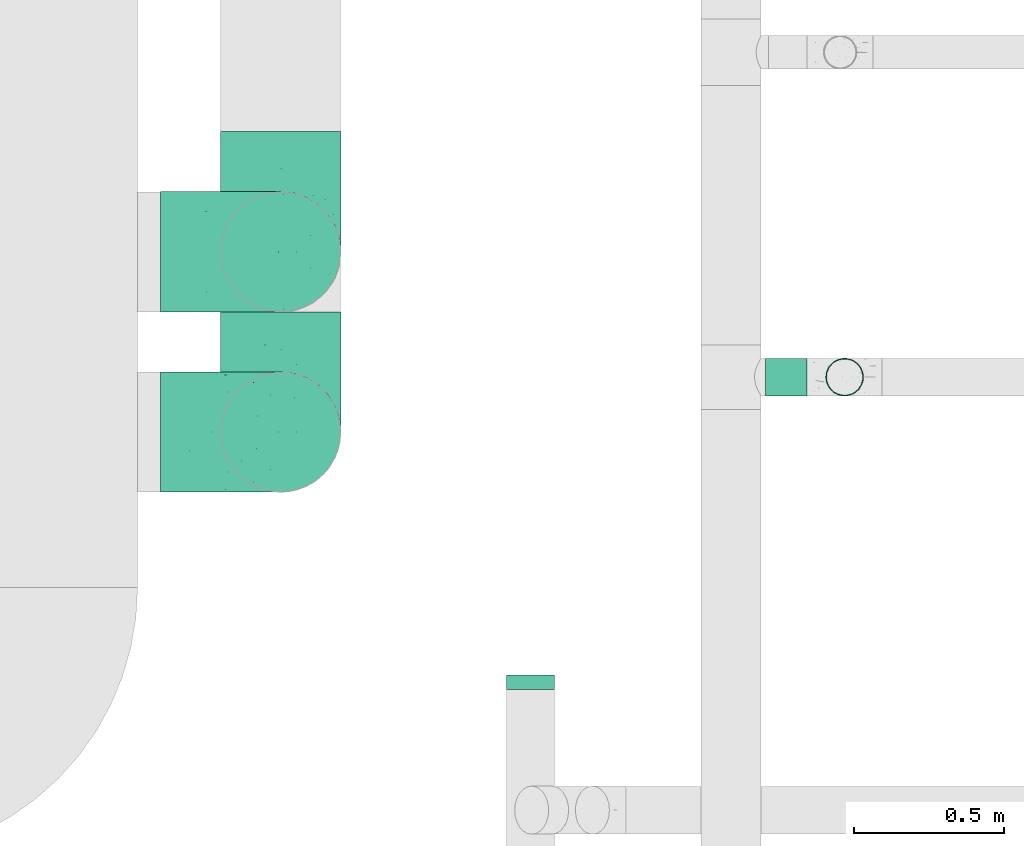
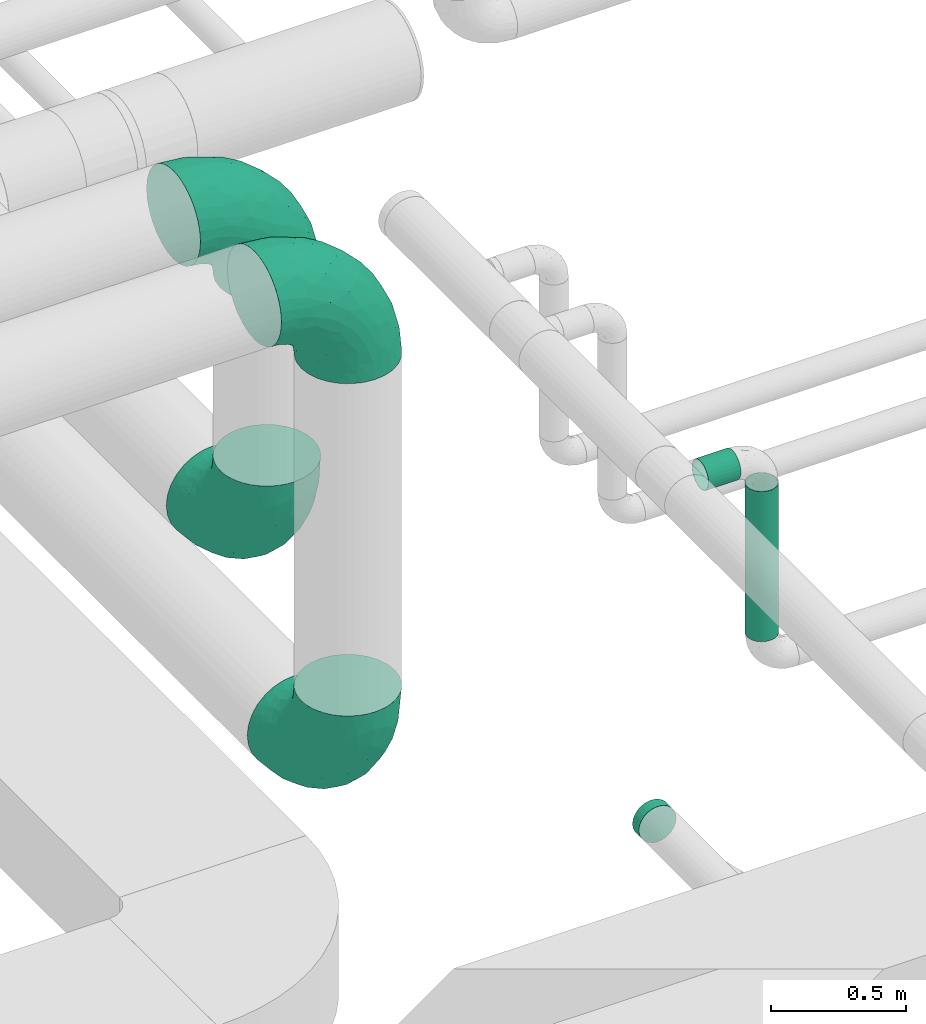
# One storey, part 64 of 91: 5 flow fittings, 2 flow segments.
"""IFC2X3 building model written with IfcOpenShell, lengths in millimetres."""

from ifc_helpers import new_model, entity, si_unit, converted_unit, derived_unit, direction, frame, origin_with_axes, origin_2d_with_axis, place, context, subcontext, project, spatial, hollow_circle, extrude, open_shell, surface_model, source, transform, mapped, material, layer, layer_set, layer_usage, type_object, element, save


model = new_model("IFC2X3")

# Units and contexts
model_context = context("Model", 3, precision=1e-05, world=origin_with_axes(), true_north=direction((0.0, 1.0)))
body_context = subcontext(model_context, "Body", "Model", "MODEL_VIEW")
ifc_project = project(units=[si_unit("AREAUNIT", "SQUARE_METRE"), si_unit("VOLUMEUNIT", "CUBIC_METRE", prefix="DECI"), si_unit("TIMEUNIT", "SECOND"), si_unit("THERMODYNAMICTEMPERATUREUNIT", "DEGREE_CELSIUS"), si_unit("PRESSUREUNIT", "PASCAL"), si_unit("MASSUNIT", "GRAM", prefix="KILO"), si_unit("LENGTHUNIT", "METRE", prefix="MILLI"), si_unit("POWERUNIT", "WATT"), si_unit("ELECTRICCURRENTUNIT", "AMPERE"), si_unit("ELECTRICVOLTAGEUNIT", "VOLT"), derived_unit("VOLUMETRICFLOWRATEUNIT", [(si_unit("VOLUMEUNIT", "CUBIC_METRE", prefix="DECI"), 1), (si_unit("TIMEUNIT", "SECOND"), -1)]), derived_unit("LINEARVELOCITYUNIT", [(si_unit("LENGTHUNIT", "METRE"), 1), (si_unit("TIMEUNIT", "SECOND"), -1)]), derived_unit("MASSDENSITYUNIT", [(si_unit("MASSUNIT", "GRAM", prefix="KILO"), 1), (si_unit("VOLUMEUNIT", "CUBIC_METRE"), -1)]), converted_unit("PLANEANGLEUNIT", "DEGREE", entity("IfcRatioMeasure", 0.01745), si_unit("PLANEANGLEUNIT", "RADIAN"), dimensions=[0, 0, 0, 0, 0, 0, 0])], contexts=[model_context])

# Site, building, storey
site_placement = place(None, origin_with_axes())
site = spatial("IfcSite", under=ifc_project, at=site_placement, CompositionType="ELEMENT")
building_placement = place(site_placement, origin_with_axes())
building = spatial("IfcBuilding", under=site, at=building_placement, Name="mc-building", CompositionType="ELEMENT")
storey_placement = place(building_placement, frame((0.0, 0.0, 8700.0), z_axis=(0.0, 0.0, 1.0), x_axis=(1.0, 0.0, 0.0)))
storey = spatial("IfcBuildingStorey", under=building, at=storey_placement, CompositionType="ELEMENT", Elevation=8700.0)

# Flow fittings
duct_fitting_type_1 = type_object("IfcDuctFittingType", Name="EPF", PredefinedType="OBSTRUCTION")
shared_shape_1 = source(origin_with_axes(), body_context, "Body", "SurfaceModel", [
    surface_model("IfcShellBasedSurfaceModel", [(0.0, 0.0, -80.0), (0.0, 56.56854, 56.56854), (0.0, 20.70552, -77.27406), (0.0, 40.0, -69.28203), (0.0, 56.56854, -56.56854), (0.0, 69.28203, -40.0), (0.0, 69.28203, 40.0), (0.0, -77.27406, -20.70552), (0.0, -77.27406, 20.70552), (0.0, -56.56854, -56.56854), (0.0, -69.28203, -40.0), (0.0, -40.0, -69.28203), (0.0, -20.70552, -77.27406), (0.0, -80.0, 0.0), (0.0, 77.27406, -20.70552), (0.0, 77.27406, 20.70552), (0.0, 40.0, 69.28203), (0.0, 20.70552, 77.27406), (0.0, 0.0, 80.0), (0.0, -69.28203, 40.0), (0.0, -56.56854, 56.56854), (0.0, -40.0, 69.28203), (0.0, -20.70552, 77.27406), (0.0, 80.0, 0.0), (48.0, 20.70552, -77.27406), (48.0, 56.56854, 56.56854), (48.0, 0.0, -80.0), (48.0, 56.56854, -56.56854), (48.0, 40.0, -69.28203), (48.0, 69.28203, -40.0), (48.0, 69.28203, 40.0), (48.0, -80.0, 0.0), (48.0, -77.27406, 20.70552), (48.0, -40.0, -69.28203), (48.0, -69.28203, -40.0), (48.0, -56.56854, -56.56854), (48.0, -20.70552, -77.27406), (48.0, -77.27406, -20.70552), (48.0, 77.27406, 20.70552), (48.0, 77.27406, -20.70552), (48.0, 20.70552, 77.27406), (48.0, 40.0, 69.28203), (48.0, 0.0, 80.0), (48.0, -69.28203, 40.0), (48.0, -56.56854, 56.56854), (48.0, -40.0, 69.28203), (48.0, -20.70552, 77.27406), (48.0, 80.0, 0.0)], [open_shell([[[0, 1, 2]], [[3, 2, 4]], [[5, 4, 6]], [[6, 4, 2]], [[0, 7, 8]], [[9, 10, 11]], [[0, 12, 11]], [[11, 10, 0]], [[0, 10, 7]], [[13, 8, 7]], [[14, 5, 15]], [[5, 6, 15]], [[2, 1, 6]], [[16, 0, 17]], [[16, 1, 0]], [[0, 18, 17]], [[0, 19, 20]], [[19, 0, 8]], [[0, 21, 22]], [[21, 0, 20]], [[0, 22, 18]], [[23, 14, 15]], [[24, 25, 26]], [[27, 24, 28]], [[29, 30, 27]], [[27, 30, 24]], [[31, 26, 32]], [[33, 34, 35]], [[31, 33, 36]], [[34, 31, 37]], [[31, 34, 33]], [[36, 26, 31]], [[38, 29, 39]], [[30, 29, 38]], [[24, 30, 25]], [[40, 26, 41]], [[26, 25, 41]], [[42, 26, 40]], [[43, 32, 26]], [[44, 43, 26]], [[45, 44, 26]], [[45, 26, 46]], [[42, 46, 26]], [[38, 39, 47]], [[18, 42, 40]], [[17, 40, 41]], [[18, 40, 17]], [[16, 25, 1]], [[16, 17, 41]], [[25, 16, 41]], [[38, 47, 23]], [[30, 38, 6]], [[1, 30, 6]], [[15, 6, 38]], [[23, 15, 38]], [[30, 1, 25]], [[23, 47, 39]], [[14, 39, 29]], [[23, 39, 14]], [[5, 27, 4]], [[5, 14, 29]], [[27, 5, 29]], [[3, 28, 24]], [[2, 24, 26]], [[4, 28, 3]], [[2, 3, 24]], [[0, 2, 26]], [[28, 4, 27]], [[0, 26, 36]], [[12, 36, 33]], [[0, 36, 12]], [[11, 35, 9]], [[11, 12, 33]], [[35, 11, 33]], [[37, 31, 13]], [[34, 37, 10]], [[10, 9, 34]], [[7, 10, 37]], [[37, 13, 7]], [[34, 9, 35]], [[13, 31, 32]], [[8, 32, 43]], [[13, 32, 8]], [[19, 44, 20]], [[19, 8, 43]], [[44, 19, 43]], [[46, 42, 22]], [[45, 46, 22]], [[20, 45, 21]], [[18, 22, 42]], [[45, 22, 21]], [[45, 20, 44]]])]),
])
flow_fitting_placement = place(storey_placement, frame((32697.05242, 5264.20513, 668.0), z_axis=(0.0, 0.0, 1.0), x_axis=(0.0, 1.0, 0.0)))
element("IfcFlowFitting", 1, at=flow_fitting_placement, inside=storey, type_object=duct_fitting_type_1, context=body_context, shape_type="MappedRepresentation", body=[
    mapped(shared_shape_1, transform((0.0, 0.0, 0.0), scale=1.0)),
])
duct_fitting_type_2 = type_object("IfcDuctFittingType", Name="BU", PredefinedType="BEND")
shared_shape_2 = source(origin_with_axes(), body_context, "Body", "SurfaceModel", [
    surface_model("IfcShellBasedSurfaceModel", [(-400.0, 0.0, -200.0), (-400.0, -44.50419, -194.98559), (-400.0, 44.50419, -194.98559), (-400.0, 194.98559, 44.50419), (-400.0, 86.77674, -180.19378), (-400.0, 180.19378, -86.77674), (-400.0, 156.36629, -124.69796), (-400.0, 124.69796, -156.36629), (-400.0, -200.0, 0.0), (-400.0, -180.19378, 86.77674), (-400.0, -124.69796, -156.36629), (-400.0, -86.77674, -180.19378), (-400.0, -156.36629, -124.69796), (-400.0, -180.19378, -86.77674), (-400.0, -194.98559, -44.50419), (-400.0, 194.98559, -44.50419), (-400.0, 180.19378, 86.77674), (-400.0, 156.36629, 124.69796), (-400.0, 124.69796, 156.36629), (-400.0, 86.77674, 180.19378), (-400.0, 0.0, 200.0), (-400.0, 44.50419, 194.98559), (-400.0, -156.36629, 124.69796), (-400.0, -124.69796, 156.36629), (-400.0, -194.98559, 44.50419), (-400.0, -86.77674, 180.19378), (-400.0, -44.50419, 194.98559), (-400.0, 200.0, 0.0), (-194.98559, 400.0, 44.50419), (0.0, 400.0, -200.0), (-44.50419, 400.0, -194.98559), (-86.77674, 400.0, -180.19378), (-156.36629, 400.0, -124.69796), (-180.19378, 400.0, -86.77674), (-200.0, 400.0, 0.0), (-124.69796, 400.0, -156.36629), (156.36629, 400.0, -124.69796), (194.98559, 400.0, 44.50419), (86.77674, 400.0, -180.19378), (44.50419, 400.0, -194.98559), (124.69796, 400.0, -156.36629), (180.19378, 400.0, -86.77674), (194.98559, 400.0, -44.50419), (200.0, 400.0, 0.0), (-194.98559, 400.0, -44.50419), (-180.19378, 400.0, 86.77674), (-156.36629, 400.0, 124.69796), (-86.77674, 400.0, 180.19378), (-124.69796, 400.0, 156.36629), (-44.50419, 400.0, 194.98559), (124.69796, 400.0, 156.36629), (180.19378, 400.0, 86.77674), (156.36629, 400.0, 124.69796), (44.50419, 400.0, 194.98559), (86.77674, 400.0, 180.19378), (0.0, 400.0, 200.0), (-311.04439, 68.01314, 191.91169), (-360.46844, 68.4039, 188.77667), (-352.32006, 35.77277, 197.31443), (-330.54073, 6.0769, 200.0), (-263.19195, 24.12295, 200.0), (-213.51486, 270.31924, 100.59997), (-187.15609, 311.12218, 106.40641), (-204.91231, 317.36362, 67.86963), (-200.0, 53.58984, 200.0), (-197.74345, 111.1477, 194.30767), (-247.23242, 72.38885, 196.25526), (-256.68864, 256.68864, 32.58839), (-289.82519, 224.65778, 52.75457), (-248.54408, 248.5441, 73.99336), (-243.63371, 275.30204, 0.0), (-275.30204, 243.63371, 0.0), (-142.1827, 142.1827, 196.84374), (-142.88496, 93.58222, 200.0), (-271.45089, 124.32551, 175.54833), (-220.85071, 146.63576, 178.75804), (-259.76957, 175.46191, 147.316), (-350.66929, 110.58045, 169.34484), (-340.12953, 148.44794, 141.42136), (-308.54163, 188.2521, 106.4064), (-351.09401, 194.51642, 66.05581), (-361.24445, 172.62407, 106.40641), (-360.07224, 201.09774, 33.76184), (-300.36348, 163.70814, 139.24948), (-311.87682, 130.51714, 162.58441), (-194.26672, 352.15536, 66.05581), (-199.37996, 369.83655, 33.78914), (-206.63477, 338.94363, 33.20511), (-93.58222, 142.88496, 200.0), (-53.58984, 200.0, 200.0), (-111.1477, 197.74345, 194.30767), (-317.55983, 204.17269, 69.52389), (-333.06107, 208.69956, 32.59419), (-313.22325, 219.80622, 0.0), (-355.49582, 205.01441, 0.0), (-24.12295, 263.19195, 200.0), (-6.0769, 330.54073, 200.0), (-68.56573, 311.19245, 191.74293), (-217.40303, 217.40306, 141.07295), (-260.37399, 213.70418, 109.76458), (-125.42721, 271.96463, 174.87928), (-174.99626, 268.83246, 143.26342), (-163.21769, 225.3825, 169.72807), (-72.38885, 247.23242, 196.25526), (-35.77867, 352.31316, 197.31361), (-148.14225, 341.4288, 141.42136), (-110.51136, 351.07639, 169.34484), (-172.56981, 361.56427, 106.40641), (-224.65778, 289.82519, 52.75457), (-216.74424, 312.71216, 34.40997), (-68.38951, 360.58933, 188.77667), (-205.01441, 355.49582, 0.0), (-101.81453, 306.09531, 179.9031), (-130.71004, 312.65493, 162.27954), (-160.73603, 304.83801, 140.32812), (-143.50466, 203.50273, 184.62979), (-170.45511, 170.45511, 185.25303), (-314.32991, 100.10105, 179.54827), (-231.94286, 241.59953, 106.86055), (-203.62398, 249.73912, 129.12471), (-203.18683, 188.09564, 166.50592), (-219.80622, 313.22325, 0.0), (-361.56427, 172.56981, -106.40641), (-311.12218, 187.15609, -106.4064), (-341.4288, 148.14225, -141.42136), (-369.83655, 199.37996, -33.78914), (-360.58933, 68.38951, -188.77667), (-352.31316, 35.77867, -197.31361), (-304.83801, 160.73603, -140.32812), (-268.83248, 174.99626, -143.26341), (-271.96463, 125.42721, -174.87928), (-270.31924, 213.51487, -100.59997), (-351.07639, 110.51136, -169.34484), (-312.71216, 216.74424, -34.40997), (-289.82519, 224.65778, -52.75457), (-317.36362, 204.91231, -67.86963), (-352.15536, 194.26672, -66.05581), (-68.01314, 311.04439, -191.91169), (-68.4039, 360.4684, -188.77667), (-35.77277, 352.32006, -197.31443), (-142.1827, 142.1827, -196.84374), (-111.1477, 197.74345, -194.30767), (-93.58222, 142.88496, -200.0), (-142.88496, 93.58222, -200.0), (-200.0, 53.58984, -200.0), (-197.74345, 111.1477, -194.30767), (-204.17269, 317.55983, -69.52389), (-208.69954, 333.06107, -32.5942), (-194.51642, 351.09401, -66.05581), (-217.40303, 217.40306, -141.07295), (-213.70418, 260.37401, -109.76458), (-175.46191, 259.76955, -147.316), (-256.68864, 256.68864, -32.58839), (-247.23242, 72.38885, -196.25526), (-188.2521, 308.54167, -106.40641), (-172.62407, 361.24445, -106.40641), (-225.3825, 163.21769, -169.72807), (-203.50273, 143.50466, -184.62979), (-224.65778, 289.82519, -52.75457), (-248.54408, 248.5441, -73.99336), (-263.19195, 24.12295, -200.0), (-124.32551, 271.45089, -175.54831), (-163.70814, 300.36348, -139.24948), (-130.51714, 311.87682, -162.58441), (-148.44794, 340.12953, -141.42136), (-110.58045, 350.66929, -169.34484), (-201.09774, 360.07224, -33.76184), (-338.94363, 206.63477, -33.20511), (-146.63576, 220.85071, -178.75804), (-53.58984, 200.0, -200.0), (-72.38885, 247.23242, -196.25526), (-24.12295, 263.19195, -200.0), (-330.54073, 6.0769, -200.0), (-311.19245, 68.56573, -191.74293), (-6.0769, 330.54073, -200.0), (-306.09531, 101.81453, -179.9031), (-312.65497, 130.71004, -162.27954), (-170.45511, 170.45511, -185.25303), (-100.10105, 314.32991, -179.54827), (-241.59952, 231.94287, -106.86055), (-249.73912, 203.62398, -129.1247), (-188.09562, 203.18687, -166.50592), (-184.86177, -7.68945, -190.47945), (-47.3167, 68.9898, -181.64929), (43.28019, 97.94399, -146.26158), (-89.73868, -8.19462, -165.20748), (-284.08539, -23.9259, -196.06307), (-237.5194, -91.23123, -161.91366), (-285.29972, -62.21993, -184.899), (-107.30881, 56.88415, -193.38949), (-40.67465, 138.05292, -194.94777), (-131.25683, -108.81981, -96.04201), (-173.32759, -100.47387, -132.95037), (-35.15296, -20.32579, -124.42291), (108.22035, 131.82436, -97.48026), (127.15077, 249.03547, -134.14487), (162.73774, 297.11528, -101.94821), (45.84323, 55.57656, -115.34749), (15.96955, -15.96955, -67.48698), (-7.08356, -53.44974, 0.0), (53.44974, 7.08356, 0.0), (-304.96267, -182.15098, -62.88188), (66.48451, 298.1029, -184.38073), (23.16668, 169.83785, -182.54712), (22.2395, 260.55544, -194.94777), (-314.6111, -193.89287, 0.0), (-267.95143, -157.40498, -100.64249), (-150.75099, -145.7792, 0.0), (-230.96047, -175.69578, 0.0), (-197.18453, -157.02261, -53.19126), (-79.21044, -98.23441, -53.99454), (-294.12651, -135.91456, -136.39782), (156.86435, 197.34569, -53.92463), (98.27322, 80.18275, -55.7234), (101.78843, 289.17601, -164.41149), (86.29858, 191.80922, -152.84552), (97.15018, 155.27637, -127.46493), (182.19126, 305.22832, -62.89092), (104.75212, 75.61551, 0.0), (145.7792, 150.75099, 0.0), (-75.61551, -104.75212, 0.0), (193.89287, 314.6111, 0.0), (175.69578, 230.96047, 0.0), (98.27322, 80.18275, 55.7234), (-267.95143, -157.40498, 100.64249), (-197.18453, -157.02261, 53.19126), (-131.25683, -108.81981, 96.04201), (-304.96267, -182.15098, 62.88188), (108.22035, 131.82436, 97.48026), (156.86435, 197.34569, 53.92463), (162.73774, 297.11528, 101.94821), (-79.21044, -98.23441, 53.99454), (93.17167, 148.03003, 127.83594), (127.15077, 249.03547, 134.14487), (86.29858, 191.80922, 152.84552), (15.96955, -15.96955, 67.48698), (-173.32759, -100.47387, 132.95037), (-237.5194, -91.23123, 161.91366), (-294.12651, -135.91456, 136.39782), (-284.08539, -23.9259, 196.06307), (182.19126, 305.22832, 62.89092), (23.16668, 169.83785, 182.54712), (101.78843, 289.17601, 164.41149), (66.48451, 298.1029, 184.38073), (-107.30881, 56.88415, 193.38949), (-285.29972, -62.21993, 184.899), (-184.86177, -7.68945, 190.47945), (22.2395, 260.55544, 194.94777), (-40.67465, 138.05292, 194.94777), (-47.3167, 68.9898, 181.64929), (45.25548, 52.88294, 113.64735), (-89.73868, -8.19462, 165.20748), (43.28019, 97.94399, 146.26158), (-35.15296, -20.32579, 124.42291)], [open_shell([[[0, 1, 2]], [[2, 3, 4]], [[3, 5, 6]], [[6, 7, 3]], [[3, 7, 4]], [[2, 8, 9]], [[10, 8, 11]], [[2, 1, 11]], [[8, 12, 13]], [[13, 14, 8]], [[8, 10, 12]], [[11, 8, 2]], [[5, 3, 15]], [[2, 16, 3]], [[17, 16, 2]], [[18, 2, 19]], [[19, 2, 20]], [[2, 18, 17]], [[19, 20, 21]], [[22, 23, 9]], [[8, 24, 9]], [[25, 26, 20]], [[20, 23, 25]], [[9, 23, 20]], [[2, 9, 20]], [[27, 15, 3]], [[28, 29, 30]], [[31, 28, 30]], [[32, 33, 34]], [[34, 35, 32]], [[31, 35, 34]], [[36, 29, 37]], [[29, 38, 39]], [[29, 40, 38]], [[40, 29, 36]], [[36, 37, 41]], [[42, 41, 37]], [[42, 37, 43]], [[44, 34, 33]], [[28, 45, 29]], [[29, 45, 46]], [[47, 29, 48]], [[29, 47, 49]], [[46, 48, 29]], [[50, 29, 49]], [[51, 50, 52]], [[37, 29, 51]], [[53, 54, 49]], [[29, 50, 51]], [[49, 54, 50]], [[53, 49, 55]], [[34, 28, 31]], [[56, 57, 58]], [[20, 59, 58]], [[60, 56, 59]], [[61, 62, 63]], [[64, 65, 66]], [[67, 68, 69]], [[60, 64, 66]], [[70, 71, 67]], [[72, 65, 73]], [[74, 75, 76]], [[77, 18, 19]], [[64, 73, 65]], [[17, 18, 78]], [[79, 80, 81]], [[27, 3, 82]], [[74, 83, 84]], [[16, 17, 81]], [[85, 86, 87]], [[81, 17, 78]], [[19, 21, 57]], [[88, 89, 90]], [[80, 3, 16]], [[91, 92, 80]], [[78, 18, 77]], [[92, 93, 94]], [[95, 96, 97]], [[88, 72, 73]], [[66, 74, 56]], [[98, 99, 76]], [[71, 93, 68]], [[100, 101, 102]], [[103, 90, 89]], [[55, 49, 104]], [[28, 86, 85]], [[65, 75, 74]], [[105, 106, 48]], [[82, 80, 92]], [[90, 103, 100]], [[84, 78, 77]], [[46, 45, 107]], [[108, 109, 70]], [[46, 107, 105]], [[49, 110, 104]], [[63, 62, 85]], [[46, 105, 48]], [[45, 28, 85]], [[101, 62, 61]], [[48, 106, 47]], [[34, 111, 86]], [[70, 67, 108]], [[47, 110, 49]], [[105, 107, 62]], [[112, 106, 113]], [[114, 101, 100]], [[115, 100, 102]], [[90, 115, 72]], [[75, 65, 116]], [[89, 95, 103]], [[68, 93, 92]], [[99, 68, 79]], [[61, 108, 69]], [[63, 85, 87]], [[79, 81, 78]], [[80, 16, 81]], [[57, 77, 19]], [[117, 74, 84]], [[45, 85, 107]], [[62, 107, 85]], [[113, 106, 105]], [[106, 112, 110]], [[95, 97, 103]], [[103, 97, 112]], [[74, 66, 65]], [[56, 60, 66]], [[90, 72, 88]], [[65, 72, 116]], [[61, 118, 119]], [[113, 114, 100]], [[61, 119, 101]], [[98, 120, 102]], [[102, 101, 119]], [[115, 102, 116]], [[116, 120, 75]], [[75, 120, 76]], [[118, 98, 119]], [[84, 83, 78]], [[68, 99, 69]], [[79, 76, 99]], [[102, 120, 116]], [[76, 120, 98]], [[106, 110, 47]], [[104, 97, 96]], [[97, 104, 110]], [[55, 104, 96]], [[58, 57, 21]], [[57, 56, 117]], [[20, 58, 21]], [[56, 58, 59]], [[117, 84, 77]], [[83, 74, 76]], [[76, 79, 83]], [[79, 78, 83]], [[57, 117, 77]], [[74, 117, 56]], [[113, 105, 114]], [[112, 113, 100]], [[105, 62, 114]], [[62, 101, 114]], [[103, 112, 100]], [[112, 97, 110]], [[68, 67, 71]], [[108, 67, 69]], [[82, 92, 94]], [[80, 79, 91]], [[79, 68, 91]], [[68, 92, 91]], [[27, 82, 94]], [[3, 80, 82]], [[34, 86, 28]], [[87, 86, 111]], [[111, 121, 87]], [[109, 87, 121]], [[109, 63, 87]], [[61, 63, 108]], [[61, 69, 118]], [[102, 119, 98]], [[69, 99, 118]], [[98, 118, 99]], [[72, 115, 116]], [[100, 115, 90]], [[70, 109, 121]], [[63, 109, 108]], [[122, 123, 124]], [[125, 27, 94]], [[2, 126, 127]], [[128, 129, 130]], [[131, 129, 123]], [[7, 132, 4]], [[6, 124, 7]], [[133, 71, 134]], [[131, 123, 135]], [[136, 135, 123]], [[137, 138, 139]], [[140, 141, 142]], [[122, 6, 5]], [[143, 144, 145]], [[2, 127, 0]], [[146, 147, 148]], [[124, 132, 7]], [[149, 150, 151]], [[71, 70, 152]], [[145, 144, 153]], [[154, 148, 155]], [[153, 130, 145]], [[4, 126, 2]], [[130, 129, 156]], [[6, 122, 124]], [[140, 145, 157]], [[152, 158, 159]], [[144, 160, 153]], [[71, 152, 134]], [[161, 162, 163]], [[33, 148, 44]], [[155, 32, 164]], [[165, 35, 31]], [[44, 166, 34]], [[5, 15, 136]], [[32, 35, 164]], [[15, 125, 136]], [[33, 32, 155]], [[136, 125, 167]], [[165, 164, 35]], [[141, 168, 161]], [[142, 141, 169]], [[166, 148, 147]], [[170, 169, 141]], [[161, 168, 151]], [[147, 121, 111]], [[170, 171, 169]], [[160, 172, 173]], [[29, 174, 139]], [[70, 121, 158]], [[163, 164, 165]], [[171, 137, 174]], [[138, 31, 30]], [[175, 132, 176]], [[168, 141, 177]], [[142, 143, 140]], [[170, 161, 137]], [[157, 130, 156]], [[158, 121, 147]], [[150, 158, 154]], [[131, 134, 159]], [[135, 136, 167]], [[154, 155, 164]], [[148, 33, 155]], [[138, 165, 31]], [[178, 161, 163]], [[5, 136, 122]], [[123, 122, 136]], [[176, 132, 124]], [[132, 175, 126]], [[160, 173, 153]], [[153, 173, 175]], [[161, 170, 141]], [[137, 171, 170]], [[145, 140, 143]], [[141, 140, 177]], [[131, 179, 180]], [[176, 128, 130]], [[131, 180, 129]], [[149, 181, 156]], [[156, 129, 180]], [[157, 156, 177]], [[177, 181, 168]], [[168, 181, 151]], [[179, 149, 180]], [[163, 162, 164]], [[158, 150, 159]], [[154, 151, 150]], [[156, 181, 177]], [[151, 181, 149]], [[132, 126, 4]], [[127, 173, 172]], [[173, 127, 126]], [[0, 127, 172]], [[139, 138, 30]], [[138, 137, 178]], [[29, 139, 30]], [[137, 139, 174]], [[178, 163, 165]], [[162, 161, 151]], [[151, 154, 162]], [[154, 164, 162]], [[138, 178, 165]], [[161, 178, 137]], [[176, 124, 128]], [[175, 176, 130]], [[124, 123, 128]], [[123, 129, 128]], [[153, 175, 130]], [[175, 173, 126]], [[158, 152, 70]], [[134, 152, 159]], [[166, 147, 111]], [[148, 154, 146]], [[154, 158, 146]], [[158, 147, 146]], [[34, 166, 111]], [[44, 148, 166]], [[27, 125, 15]], [[167, 125, 94]], [[94, 93, 167]], [[133, 167, 93]], [[133, 135, 167]], [[131, 135, 134]], [[131, 159, 179]], [[156, 180, 149]], [[159, 150, 179]], [[149, 179, 150]], [[140, 157, 177]], [[130, 157, 145]], [[71, 133, 93]], [[135, 133, 134]], [[160, 144, 182]], [[183, 184, 185]], [[186, 1, 0]], [[187, 11, 188]], [[0, 172, 186]], [[182, 187, 188]], [[189, 142, 190]], [[191, 192, 193]], [[182, 186, 160]], [[182, 185, 187]], [[189, 144, 143]], [[194, 195, 196]], [[197, 198, 193]], [[199, 198, 200]], [[14, 13, 201]], [[202, 203, 204]], [[205, 8, 14]], [[182, 183, 185]], [[12, 206, 13]], [[184, 183, 203]], [[207, 208, 209]], [[207, 209, 210]], [[12, 211, 206]], [[14, 201, 205]], [[210, 191, 198]], [[182, 188, 186]], [[194, 212, 213]], [[193, 198, 191]], [[206, 211, 192]], [[214, 202, 38]], [[11, 187, 10]], [[215, 214, 195]], [[204, 171, 174]], [[40, 214, 38]], [[190, 204, 203]], [[169, 204, 190]], [[195, 216, 215]], [[12, 10, 211]], [[189, 183, 182]], [[188, 11, 1]], [[36, 195, 40]], [[208, 205, 201]], [[209, 201, 206]], [[204, 29, 39]], [[192, 191, 206]], [[191, 210, 209]], [[142, 169, 190]], [[198, 197, 213]], [[215, 203, 214]], [[196, 41, 217]], [[218, 213, 219]], [[210, 199, 220]], [[221, 222, 217]], [[29, 204, 174]], [[221, 42, 43]], [[212, 217, 222]], [[183, 190, 203]], [[40, 195, 214]], [[190, 183, 189]], [[212, 222, 219]], [[36, 41, 196]], [[213, 200, 198]], [[202, 39, 38]], [[171, 204, 169]], [[209, 206, 191]], [[42, 217, 41]], [[10, 187, 211]], [[211, 187, 192]], [[187, 185, 192]], [[193, 185, 184]], [[185, 193, 192]], [[193, 184, 197]], [[221, 217, 42]], [[212, 194, 196]], [[196, 217, 212]], [[195, 36, 196]], [[206, 201, 13]], [[201, 209, 208]], [[203, 202, 214]], [[39, 202, 204]], [[199, 210, 198]], [[207, 210, 220]], [[144, 189, 182]], [[142, 189, 143]], [[219, 213, 212]], [[200, 213, 218]], [[1, 186, 188]], [[160, 186, 172]], [[216, 195, 194]], [[203, 215, 184]], [[197, 216, 194]], [[184, 215, 216]], [[216, 197, 184]], [[197, 194, 213]], [[8, 205, 24]], [[223, 200, 218]], [[224, 225, 226]], [[208, 227, 205]], [[208, 225, 227]], [[228, 229, 230]], [[207, 220, 231]], [[232, 233, 234]], [[199, 235, 231]], [[236, 237, 238]], [[239, 60, 59]], [[225, 208, 207]], [[222, 221, 240]], [[199, 200, 235]], [[241, 242, 243]], [[23, 237, 25]], [[244, 88, 73]], [[239, 245, 246]], [[235, 226, 231]], [[55, 247, 53]], [[247, 243, 53]], [[20, 26, 239]], [[241, 248, 249]], [[60, 246, 64]], [[232, 250, 228]], [[245, 26, 25]], [[239, 26, 245]], [[22, 224, 238]], [[246, 244, 64]], [[249, 246, 251]], [[226, 225, 231]], [[24, 227, 9]], [[229, 240, 230]], [[233, 52, 50]], [[229, 219, 222]], [[22, 238, 23]], [[250, 223, 228]], [[229, 223, 219]], [[221, 43, 37]], [[250, 235, 223]], [[234, 241, 252]], [[240, 37, 51]], [[249, 248, 244]], [[221, 37, 240]], [[9, 224, 22]], [[51, 230, 240]], [[89, 88, 248]], [[244, 246, 249]], [[233, 242, 234]], [[247, 95, 89]], [[224, 9, 227]], [[242, 50, 54]], [[237, 246, 245]], [[96, 95, 247]], [[55, 96, 247]], [[247, 89, 248]], [[236, 253, 251]], [[249, 252, 241]], [[25, 237, 245]], [[241, 247, 248]], [[50, 242, 233]], [[236, 238, 224]], [[243, 242, 54]], [[229, 228, 223]], [[252, 249, 251]], [[246, 237, 251]], [[236, 224, 226]], [[237, 23, 238]], [[253, 236, 226]], [[251, 237, 236]], [[235, 253, 226]], [[251, 253, 252]], [[51, 52, 230]], [[240, 229, 222]], [[52, 233, 230]], [[228, 230, 233]], [[205, 227, 24]], [[224, 227, 225]], [[53, 243, 54]], [[241, 243, 247]], [[207, 231, 225]], [[199, 231, 220]], [[88, 244, 248]], [[64, 244, 73]], [[200, 223, 235]], [[219, 223, 218]], [[60, 239, 246]], [[239, 59, 20]], [[241, 234, 242]], [[232, 234, 252]], [[250, 252, 253]], [[233, 232, 228]], [[252, 250, 232]], [[235, 250, 253]]])]),
])
for number, where, z_axis, x_axis, name in (
    (2, (31866.56389, 6120.95522, 2971.08071), (0.0, 1.0, 0.0), (1.0, 0.0, 0.0), "BU"),
    (3, (31866.56389, 6120.95522, 668.0), (1.0, 0.0, 0.0), (0.0, 0.0, -1.0), "BU"),
    (4, (31866.56389, 6720.97227, 1344.0), (-1.0, 0.0, 0.0), (0.0, -1.0, 0.0), "BU"),
    (5, (31866.56389, 6720.97227, 2971.08071), (0.0, -1.0, 0.0), (0.0, 0.0, 1.0), "BU"),
):
    element("IfcFlowFitting", number, at=place(storey_placement, frame(where, z_axis=z_axis, x_axis=x_axis)), inside=storey, type_object=duct_fitting_type_2, Name=name, context=body_context, shape_type="MappedRepresentation", body=[
        mapped(shared_shape_2, transform((0.0, 0.0, 0.0), scale=1.0)),
    ])

# Flow segments
ifc_material = material(Name="FZ1")
ifc_layer = layer(ifc_material, 0.0)
ifc_layer_set = layer_set([ifc_layer], Name="FZ1")
ifc_layer_usage = layer_usage(ifc_layer_set, "AXIS1", "POSITIVE", 0.0)
duct_segment_type = type_object("IfcDuctSegmentType", Name="Safe", PredefinedType="RIGIDSEGMENT")
shared_shape_3 = source(origin_with_axes(), body_context, "Body", "SweptSolid", [
    extrude(hollow_circle(Radius=62.5, WallThickness=2.0, at=origin_2d_with_axis()), frame((0.0, 0.0, 0.0), z_axis=(1.0, 0.0, 0.0), x_axis=(0.0, 1.0, 0.0)), (0.0, 0.0, 1.0), 679.0),
])
flow_segment_1_placement = place(storey_placement, frame((33742.76981, 6304.03427, 1219.0), z_axis=(0.0, 1.0, 0.0), x_axis=(0.0, 0.0, -1.0)))
element("IfcFlowSegment", 6, at=flow_segment_1_placement, inside=storey, type_object=duct_segment_type, material=ifc_layer_usage, Name="Safe", context=body_context, shape_type="MappedRepresentation", body=[
    mapped(shared_shape_3, transform((0.0, 0.0, 0.0), scale=1.0)),
])
shared_shape_4 = source(origin_with_axes(), body_context, "Body", "SweptSolid", [
    extrude(hollow_circle(Radius=62.5, WallThickness=2.0, at=origin_2d_with_axis()), frame((0.0, 0.0, 0.0), z_axis=(1.0, 0.0, 0.0), x_axis=(0.0, 1.0, 0.0)), (0.0, 0.0, 1.0), 138.0),
])
flow_segment_2_placement = place(storey_placement, frame((33479.76981, 6304.03427, 1344.0), z_axis=(0.0, 0.0, 1.0), x_axis=(1.0, 0.0, 0.0)))
element("IfcFlowSegment", 7, at=flow_segment_2_placement, inside=storey, type_object=duct_segment_type, material=ifc_layer_usage, Name="Safe", context=body_context, shape_type="MappedRepresentation", body=[
    mapped(shared_shape_4, transform((0.0, 0.0, 0.0), scale=1.0)),
])

save(model, "model.ifc")
